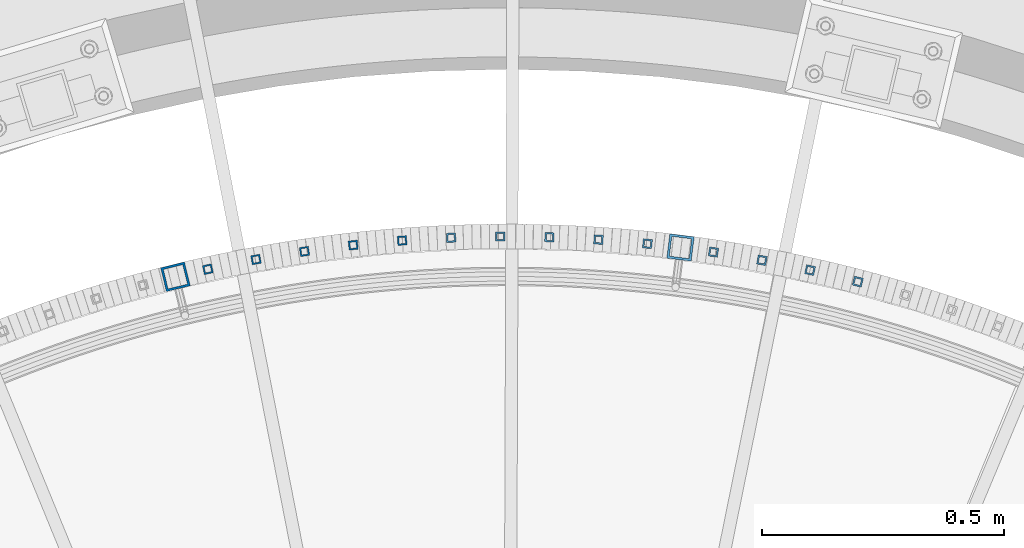
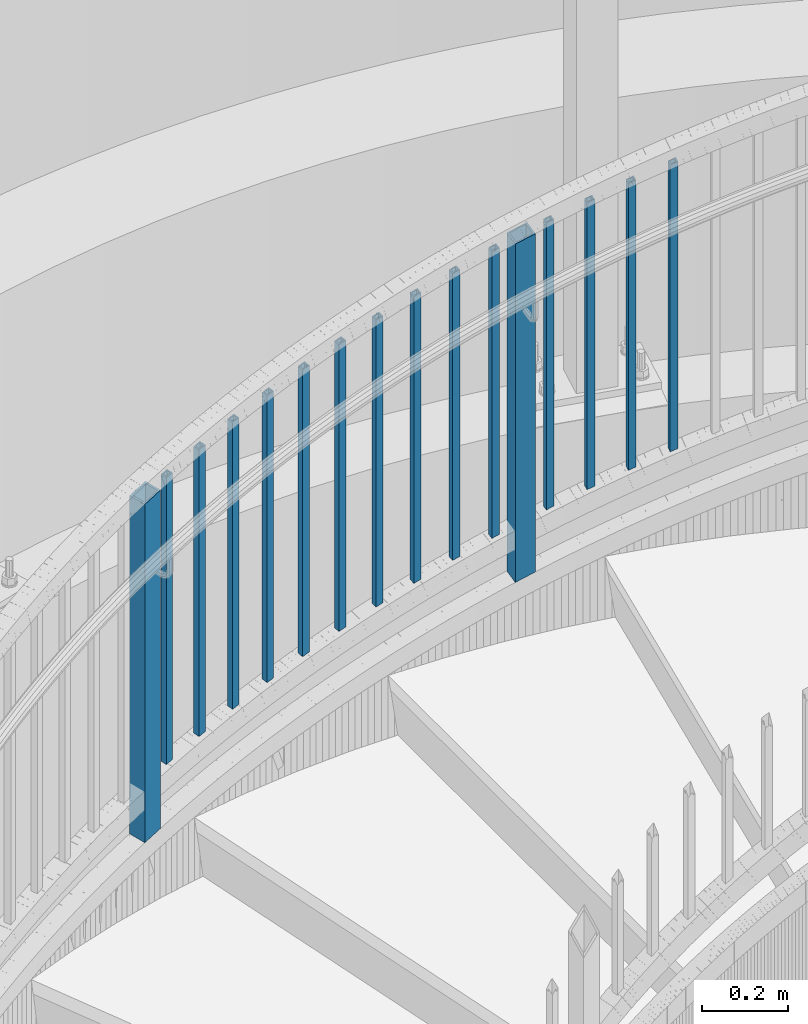
# One storey, part 270 of 975: 16 columns.
"""IFC2X3 building model written with IfcOpenShell, lengths in millimetres."""

from ifc_helpers import new_model, si_unit, frame, origin_with_axes, place, context, subcontext, project, spatial, faceted_brep, material, type_object, element, save


model = new_model("IFC2X3")

# Units and contexts
model_context = context("Model", 3, precision=1e-05, world=origin_with_axes())
body_context = subcontext(model_context, "Body", "Model", "MODEL_VIEW")
ifc_project = project(units=[si_unit("LENGTHUNIT", "METRE", prefix="MILLI"), si_unit("AREAUNIT", "SQUARE_METRE"), si_unit("VOLUMEUNIT", "CUBIC_METRE"), si_unit("MASSUNIT", "GRAM", prefix="KILO"), si_unit("TIMEUNIT", "SECOND"), si_unit("PLANEANGLEUNIT", "RADIAN"), si_unit("SOLIDANGLEUNIT", "STERADIAN"), si_unit("THERMODYNAMICTEMPERATUREUNIT", "DEGREE_CELSIUS"), si_unit("LUMINOUSINTENSITYUNIT", "LUMEN")], contexts=[model_context])

# Site, building, storey
site_placement = place(None, origin_with_axes())
site = spatial("IfcSite", under=ifc_project, at=site_placement, CompositionType="ELEMENT")
building_placement = place(site_placement, origin_with_axes())
building = spatial("IfcBuilding", under=site, at=building_placement, Name="Undefined", CompositionType="ELEMENT")
storey_placement = place(building_placement, origin_with_axes())
storey = spatial("IfcBuildingStorey", under=building, at=storey_placement, Name="Undefined", CompositionType="ELEMENT", Elevation=0.0)

# Columns
ifc_material = material()
column_type_1 = type_object("IfcColumnType", Name="HSS3/4X3/4X.120_TUBES", PredefinedType="NOTDEFINED")
for number, where, z_axis, x_axis, name in (
    (1, (35024.8508105374, 6259.07622067158, 1312.13852394143), (0.100947957956007, 0.994891707566463, 0.0), (0.0, 0.0, 1.0), "PICKET"),
    (2, (34923.619680202, 6267.56260215822, 1279.79321194143), (0.0656776139765134, 0.997840894643205, 0.0), (0.0, 0.0, 1.0), "PICKET"),
    (3, (34822.1516406156, 6272.46131241961, 1247.44789994143), (0.0303249969854733, 0.999540091521011, 0.0), (0.0, 0.0, 1.0), "PICKET"),
    (4, (34720.5738002698, 6273.76621486659, 1215.10258794143), (-0.00506560999855719, 0.999987169715363, 0.0), (0.0, 0.0, 1.0), "PICKET"),
    (5, (34619.0134052028, 6271.4756748546, 1182.75727594143), (-0.0404498700037948, 0.999181569093764, 0.0), (0.0, 0.0, 1.0), "PICKET"),
    (6, (34517.5976795992, 6265.59256173131, 1150.41196394143), (-0.0757834579938353, 0.997124298918894, 0.0), (0.0, 0.0, 1.0), "PICKET"),
    (7, (35459.8030304421, 6180.5296703431, 1452.5665403963), (0.252503492026525, 0.967595983101631, 0.0), (0.0, 0.0, 1.0), "PICKET"),
    (8, (34416.4536664171, 6256.12424524228, 1118.06665194143), (-0.111022113028295, 0.993817936253282, 0.0), (0.0, 0.0, 1.0), "PICKET"),
    (9, (35361.0790653499, 6204.45728927154, 1420.2212283963), (0.218104159966853, 0.975925496851657, 0.0), (0.0, 0.0, 1.0), "PICKET"),
    (10, (34315.7080682417, 6243.08258629891, 1085.72133994143), (-0.146121691981389, 0.989266622873983, 0.0), (0.0, 0.0, 1.0), "PICKET"),
    (11, (35261.5701878845, 6224.8762886757, 1387.8759163963), (0.183431609955449, 0.983032473761245, 0.0), (0.0, 0.0, 1.0), "PICKET"),
    (12, (34215.4870885658, 6226.48392212027, 1053.37602794143), (-0.181038224077652, 0.983476060421813, 0.0), (0.0, 0.0, 1.0), "PICKET"),
    (13, (35161.4010523048, 6241.76108978003, 1355.5306043963), (0.148529275996356, 0.988908010975742, 0.0), (0.0, 0.0, 1.0), "PICKET"),
    (14, (34115.9162736952, 6206.34904576765, 1021.03071594143), (-0.215727971103566, 0.976453502468775, 0.0), (0.0, 0.0, 1.0), "PICKET"),
):
    element("IfcColumn", number, at=place(storey_placement, frame(where, z_axis=z_axis, x_axis=x_axis)), inside=storey, type_object=column_type_1, material=ifc_material, Name=name, ObjectType="HSS3/4X3/4X.120_TUBES", context=body_context, shape_type="Brep", body=[
        faceted_brep([(48.9778304891588, 6.35000000000036, -6.34999999999854), (44.9444858438005, -6.35000000000582, -6.34999999999127), (858.946568247068, -6.35000000000582, -6.34999999999127), (863.063419332087, 6.35000000000036, -6.34999999999854), (44.9444858438051, -6.35000000000036, 6.35000000000582), (858.946568247072, -6.35000000000036, 6.35000000000582), (48.9778304891634, 6.350000000004, 6.34999999999854), (863.063419332091, 6.350000000004, 6.34999999999854), (49.9861666504976, 9.52499999999964, -9.52500000000146), (49.9861666505039, 9.52500000000691, 9.52499999999418), (864.092632103347, 9.52500000000691, 9.52499999999418), (864.09263210334, 9.52499999999964, -9.52500000000146), (43.9361496824667, -9.52500000000146, 9.52500000001601), (857.917355475819, -9.52500000000146, 9.52500000001601), (43.9361496824599, -9.52500000000691, -9.52499999997963), (857.917355475812, -9.52500000000691, -9.52499999997963)], [[[0, 1, 2, 3]], [[1, 4, 5, 2]], [[4, 6, 7, 5]], [[6, 0, 3, 7]], [[8, 9, 10, 11]], [[9, 12, 13, 10]], [[12, 14, 15, 13]], [[14, 8, 11, 15]], [[13, 15, 11, 10], [5, 7, 3, 2]], [[14, 12, 9, 8], [6, 4, 1, 0]]]),
    ])
column_type_2 = type_object("IfcColumnType", Name="HSS2X2X.188_TUBES", PredefinedType="NOTDEFINED")
for number, where, z_axis, x_axis, name in (
    (15, (35093.237436469, 6251.29301218997, 1181.18808981449), (0.124986912061329, 0.992158390486808, 0.0), (0.0, 0.0, 1.0), "HANDRAIL"),
    (16, (34048.8883432272, 6190.71045638619, 846.715102991238), (-0.23887243295963, 0.971050956835916, 0.0), (0.0, 0.0, 1.0), "HANDRAIL"),
):
    element("IfcColumn", number, at=place(storey_placement, frame(where, z_axis=z_axis, x_axis=x_axis)), inside=storey, type_object=column_type_2, material=ifc_material, Name=name, ObjectType="HSS2X2X.188_TUBES", context=body_context, shape_type="Brep", body=[
        faceted_brep([(59.7770034089217, 20.6374999999425, -20.6375000000444), (46.6339334019876, -20.6375000000517, -20.6375000000335), (1006.79125658838, -20.6375000000517, -20.6375000000335), (1019.96851403156, 20.6374999999425, -20.6375000000444), (46.6339334020035, -20.6374999999389, 20.637500000048), (1006.7912565884, -20.6374999999389, 20.637500000048), (59.7770034089381, 20.6375000000517, 20.6375000000335), (1019.96851403158, 20.6375000000517, 20.6375000000335), (61.2935114866432, 25.3999999999287, -25.4000000000524), (61.2935114866632, 25.4000000000633, 25.4000000000415), (1021.48896681348, 25.4000000000633, 25.4000000000415), (1021.48896681346, 25.3999999999287, -25.4000000000524), (45.1174253242825, -25.3999999999251, 25.400000000056), (1005.27080380649, -25.3999999999251, 25.400000000056), (45.1174253242625, -25.4000000000597, -25.4000000000415), (1005.27080380647, -25.4000000000597, -25.4000000000415)], [[[0, 1, 2, 3]], [[1, 4, 5, 2]], [[4, 6, 7, 5]], [[6, 0, 3, 7]], [[8, 9, 10, 11]], [[9, 12, 13, 10]], [[12, 14, 15, 13]], [[14, 8, 11, 15]], [[13, 15, 11, 10], [5, 7, 3, 2]], [[14, 12, 9, 8], [6, 4, 1, 0]]]),
    ])

save(model, "model.ifc")
